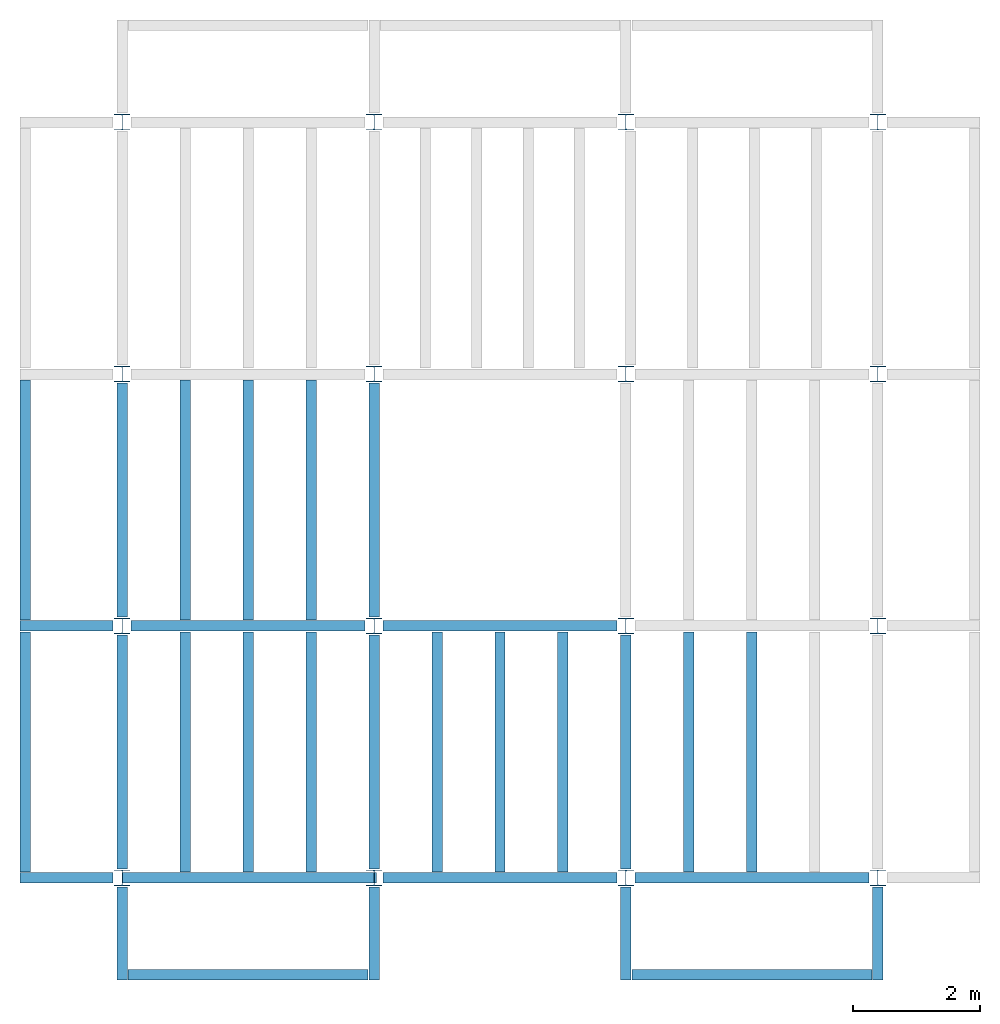
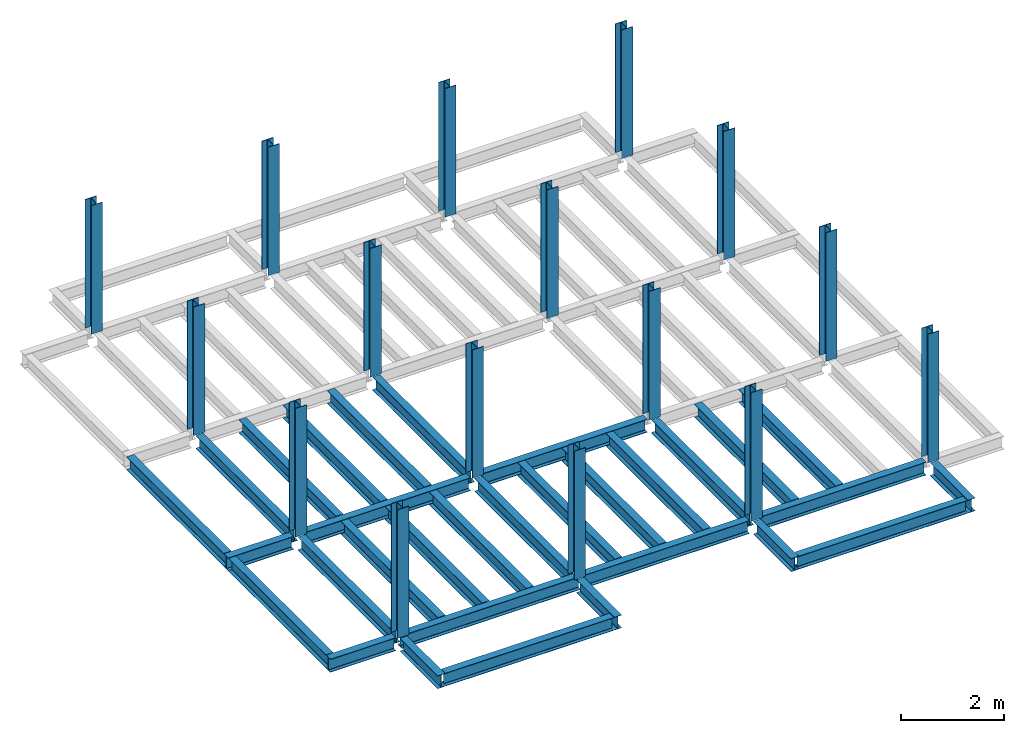
# One storey, part 1 of 3: 31 beams, 16 columns, 4 elements without a shape of their own.
"""IFC4 building model written with IfcOpenShell, lengths in feet."""

from ifc_helpers import new_model, entity, si_unit, converted_unit, derived_unit, direction, frame, origin, origin_2d, place, context, subcontext, project, spatial, line, arc, indexed_curve, i_section, outline, extrude, source, transform, mapped, material, type_object, type_shapes, element, aggregate, save


model = new_model("IFC4")

# Units and contexts
model_context = context("Model", 3, precision=0.0001, world=origin(), true_north=direction((6.123233995736766e-17, 1.0)))
plan_context = context("Plan", 3, precision=0.0001, world=origin(), true_north=direction((6.123233995736766e-17, 1.0)))
body_context = subcontext(model_context, "Body", "Model", "MODEL_VIEW")
ifc_project = project(units=[converted_unit("LENGTHUNIT", "FOOT", entity("IfcLengthMeasure", 0.3048), si_unit("LENGTHUNIT", "METRE"), dimensions=[1, 0, 0, 0, 0, 0, 0]), converted_unit("AREAUNIT", "SQUARE FOOT", entity("IfcAreaMeasure", 0.09290304), si_unit("AREAUNIT", "SQUARE_METRE"), dimensions=[2, 0, 0, 0, 0, 0, 0]), converted_unit("PLANEANGLEUNIT", "DEGREE", entity("IfcPlaneAngleMeasure", 0.017453292519943278), si_unit("PLANEANGLEUNIT", "RADIAN"), dimensions=[0, 0, 0, 0, 0, 0, 0]), converted_unit("VOLUMEUNIT", "CUBIC FOOT", entity("IfcVolumeMeasure", 0.028316846592000004), si_unit("VOLUMEUNIT", "CUBIC_METRE"), dimensions=[3, 0, 0, 0, 0, 0, 0]), si_unit("PRESSUREUNIT", "PASCAL"), derived_unit("MASSDENSITYUNIT", [(si_unit("MASSUNIT", "GRAM", prefix="KILO"), 1), (si_unit("LENGTHUNIT", "METRE"), -3)]), derived_unit("VAPORPERMEABILITYUNIT", [(si_unit("LENGTHUNIT", "METRE"), -1), (si_unit("TIMEUNIT", "SECOND"), 1)]), derived_unit("USERDEFINED", [(si_unit("MASSUNIT", "GRAM", prefix="KILO"), 1), (si_unit("LENGTHUNIT", "METRE"), 3), (si_unit("TIMEUNIT", "SECOND"), -3), (si_unit("ELECTRICCURRENTUNIT", "AMPERE"), -2)]), derived_unit("MODULUSOFELASTICITYUNIT", [(si_unit("MASSUNIT", "GRAM", prefix="KILO"), 1), (si_unit("LENGTHUNIT", "METRE"), -1), (si_unit("TIMEUNIT", "SECOND"), -2)]), derived_unit("THERMALEXPANSIONCOEFFICIENTUNIT", [(si_unit("THERMODYNAMICTEMPERATUREUNIT", "KELVIN"), -1)]), derived_unit("SPECIFICHEATCAPACITYUNIT", [(si_unit("TIMEUNIT", "SECOND"), -2), (si_unit("THERMODYNAMICTEMPERATUREUNIT", "KELVIN"), -1), (si_unit("LENGTHUNIT", "METRE"), 2)]), derived_unit("THERMALCONDUCTANCEUNIT", [(si_unit("MASSUNIT", "GRAM", prefix="KILO"), 1), (si_unit("TIMEUNIT", "SECOND"), -3), (si_unit("THERMODYNAMICTEMPERATUREUNIT", "KELVIN"), -1), (si_unit("LENGTHUNIT", "METRE"), 1)])], contexts=[model_context, plan_context])

# Site, building, storey
site_placement = place(None, origin())
site = spatial("IfcSite", under=ifc_project, at=site_placement, CompositionType="ELEMENT")
building_placement = place(site_placement, origin())
building = spatial("IfcBuilding", under=site, at=building_placement, CompositionType="ELEMENT")
storey_placement = place(building_placement, frame((0.0, 0.0, 109.875)))
storey = spatial("IfcBuildingStorey", under=building, at=storey_placement, Name="STR 12", CompositionType="ELEMENT", Elevation=109.875)

# Columns
ifc_material = material(Name="Steel ASTM A992", Category="Metal")
column_type = type_object("IfcColumnType", Name="W10X49", PredefinedType="COLUMN", material=ifc_material)
shared_shape_1 = source(origin(), body_context, "Body", "SweptSolid", [
    extrude(outline(indexed_curve([(-0.41666666666666663, -0.4166666666666676), (0.41666666666666663, -0.4166666666666676), (0.41666666666666663, -0.3699999999999996), (0.055833333333333846, -0.3699999999999996), (0.02637055078389421, -0.35779611588277277), (0.014166666666666636, -0.32833333333333287), (0.01416666666666665, 0.32833333333333303), (0.026370550783893467, 0.3577961158827727), (0.05583333333333332, 0.3700000000000003), (0.41666666666666663, 0.3700000000000003), (0.41666666666666663, 0.4166666666666656), (-0.41666666666666663, 0.4166666666666656), (-0.41666666666666663, 0.3700000000000003), (-0.05583333333333365, 0.3700000000000003), (-0.02637055078389416, 0.3577961158827734), (-0.014166666666666685, 0.32833333333333387), (-0.014166666666666685, -0.32833333333333264), (-0.026370550783893578, -0.3577961158827721), (-0.055833333333333374, -0.3699999999999996), (-0.41666666666666663, -0.3699999999999996)], segments=[line(1, 2, 3, 4), arc(4, 5, 6), line(6, 7), arc(7, 8, 9), line(9, 10, 11, 12, 13, 14), arc(14, 15, 16), line(16, 17), arc(17, 18, 19), line(19, 20, 1)], self_intersect=False)), frame((0.0, 0.0, 109.875), z_axis=(0.0, 0.0, 1.0), x_axis=(-1.0, 0.0, 0.0)), (0.0, 0.0, 1.0), 10.0),
])
type_shapes(column_type, [shared_shape_1])
for number, where, z_axis, x_axis, name in (
    (1, (0.0, 0.0, -109.875), (0.0, 0.0, 1.0), (-1.0, 0.0, 0.0), "W10X49"),
    (2, (0.0, 13.0, -109.875), (0.0, 0.0, 1.0), (-1.0, 0.0, 0.0), "W10X49"),
    (3, (0.0, 26.0, -109.875), (0.0, 0.0, 1.0), (-1.0, 0.0, 0.0), "W10X49"),
    (4, (0.0, 39.0, -109.875), (0.0, 0.0, 1.0), (-1.0, 0.0, 0.0), "W10X49"),
    (5, (13.0, 0.0, -109.875), (0.0, 0.0, 1.0), (-1.0, 0.0, 0.0), "W10X49"),
    (6, (13.0, 13.0, -109.875), (0.0, 0.0, 1.0), (-1.0, 0.0, 0.0), "W10X49"),
    (7, (13.0, 26.0, -109.875), (0.0, 0.0, 1.0), (-1.0, 0.0, 0.0), "W10X49"),
    (8, (13.0, 39.0, -109.875), (0.0, 0.0, 1.0), (-1.0, 0.0, 0.0), "W10X49"),
    (9, (26.0, 0.0, -109.875), (0.0, 0.0, 1.0), (-1.0, 0.0, 0.0), "W10X49"),
    (10, (26.0, 13.0, -109.875), (0.0, 0.0, 1.0), (-1.0, 0.0, 0.0), "W10X49"),
    (11, (26.0, 26.0, -109.875), (0.0, 0.0, 1.0), (-1.0, 0.0, 0.0), "W10X49"),
    (12, (26.0, 39.0, -109.875), (0.0, 0.0, 1.0), (-1.0, 0.0, 0.0), "W10X49"),
    (13, (39.0, 0.0, -109.875), (0.0, 0.0, 1.0), (-1.0, 0.0, 0.0), "W10X49"),
    (14, (39.0, 13.0, -109.875), (0.0, 0.0, 1.0), (-1.0, 0.0, 0.0), "W10X49"),
    (15, (39.0, 26.0, -109.875), (0.0, 0.0, 1.0), (-1.0, 0.0, 0.0), "W10X49"),
    (16, (39.0, 39.0, -109.875), (0.0, 0.0, 1.0), (-1.0, 0.0, 0.0), "W10X49"),
):
    element("IfcColumn", number, at=place(storey_placement, frame(where, z_axis=z_axis, x_axis=x_axis)), inside=storey, type_object=column_type, material=ifc_material, Name=name, ObjectType="W Shapes-Column:W10X49", PredefinedType="COLUMN", context=body_context, shape_type="MappedRepresentation", body=[
        mapped(shared_shape_1, transform((0.0, 0.0, 0.0), scale=1.0)),
    ])

# Beams
beam_type_1 = type_object("IfcBeamType", Name="W12X26", PredefinedType="JOIST", material=ifc_material)
shared_shape_2 = source(origin(), body_context, "Body", "SweptSolid", [
    extrude(outline(indexed_curve([(-0.27041666666666714, -0.47666666666666574), (-0.27041666666666714, -0.5083333333333351), (0.2704166666666669, -0.5083333333333351), (0.2704166666666669, -0.47666666666666574), (0.03458333333333309, -0.47666666666666574), (0.016905663803669493, -0.46934433619632937), (0.009583333333333202, -0.4516666666666659), (0.0095833333333332, 0.45166666666666705), (0.01690566380366948, 0.4693443361963307), (0.03458333333333325, 0.4766666666666671), (0.2704166666666669, 0.4766666666666671), (0.2704166666666669, 0.5083333333333312), (-0.2704166666666655, 0.5083333333333312), (-0.2704166666666655, 0.4766666666666671), (-0.034583333333333514, 0.47666666666666707), (-0.016905663803669865, 0.46934433619633054), (-0.009583333333333737, 0.45166666666666694), (-0.009583333333333735, -0.4516666666666658), (-0.01690566380367013, -0.4693443361963295), (-0.03458333333333368, -0.47666666666666574)], segments=[line(1, 2, 3, 4, 5), arc(5, 6, 7), line(7, 8), arc(8, 9, 10), line(10, 11, 12, 13, 14, 15), arc(15, 16, 17), line(17, 18), arc(18, 19, 20), line(20, 1)], self_intersect=False)), frame((-6.103346456692914, 0.0, 0.0), z_axis=(-1.0, 0.0, 0.0), x_axis=(0.0, -1.0, 0.0)), (0.0, 0.0, -1.0), 12.083333333333323),
])
type_shapes(beam_type_1, [shared_shape_2])
beam_1_placement = place(storey_placement, frame((6.561679790026266, 13.0, -0.50833333333334)))
element("IfcBeam", 17, at=beam_1_placement, inside=storey, type_object=beam_type_1, material=ifc_material, Name="W12X26", ObjectType="W Shapes:W12X26", PredefinedType="JOIST", context=body_context, shape_type="MappedRepresentation", body=[
    mapped(shared_shape_2, transform((0.0, 0.0, 0.0), scale=1.0)),
])
for number, where, z_axis, x_axis, name in (
    (18, (0.0, 6.561679790026247, -0.50833333333334), (0.0, 0.0, 1.0), (0.0, 1.0, 0.0), "W12X26"),
    (19, (26.0, 6.561679790026162, -0.50833333333334), (0.0, 0.0, 1.0), (0.0, 1.0, 0.0), "W12X26"),
    (20, (13.0, 6.5616797900262025, -0.50833333333334), (0.0, 0.0, 1.0), (0.0, 1.0, 0.0), "W12X26"),
):
    element("IfcBeam", number, at=place(storey_placement, frame(where, z_axis=z_axis, x_axis=x_axis)), inside=storey, type_object=beam_type_1, material=ifc_material, Name=name, ObjectType="W Shapes:W12X26", PredefinedType="JOIST", context=body_context, shape_type="MappedRepresentation", body=[
        mapped(shared_shape_2, transform((0.0, 0.0, 0.0), scale=1.0)),
    ])
beam_type_2 = type_object("IfcBeamType", Name="W12X26", PredefinedType="JOIST", material=ifc_material)
shared_shape_3 = source(origin(), body_context, "Body", "SweptSolid", [
    extrude(outline(indexed_curve([(-0.27041666666666714, -0.47666666666666574), (-0.27041666666666714, -0.5083333333333351), (0.2704166666666669, -0.5083333333333351), (0.2704166666666669, -0.47666666666666574), (0.03458333333333309, -0.47666666666666574), (0.016905663803669493, -0.46934433619632937), (0.009583333333333202, -0.4516666666666659), (0.0095833333333332, 0.45166666666666705), (0.01690566380366948, 0.4693443361963307), (0.03458333333333325, 0.4766666666666671), (0.2704166666666669, 0.4766666666666671), (0.2704166666666669, 0.5083333333333312), (-0.2704166666666655, 0.5083333333333312), (-0.2704166666666655, 0.4766666666666671), (-0.034583333333333514, 0.47666666666666707), (-0.016905663803669865, 0.46934433619633054), (-0.009583333333333737, 0.45166666666666694), (-0.009583333333333735, -0.4516666666666658), (-0.01690566380367013, -0.4693443361963295), (-0.03458333333333368, -0.47666666666666574)], segments=[line(1, 2, 3, 4, 5), arc(5, 6, 7), line(7, 8), arc(8, 9, 10), line(10, 11, 12, 13, 14, 15), arc(15, 16, 17), line(17, 18), arc(18, 19, 20), line(20, 1)], self_intersect=False)), frame((-6.226706036745409, 0.0, 0.0), z_axis=(-1.0, 0.0, 0.0), x_axis=(0.0, -1.0, 0.0)), (0.0, 0.0, -1.0), 12.08333333333333),
])
type_shapes(beam_type_2, [shared_shape_3])
for number, where, name in (
    (21, (19.68503937007876, 13.0, -0.50833333333334), "W12X26"),
    (22, (19.68503937007874, 0.0, -0.50833333333334), "W12X26"),
):
    element("IfcBeam", number, at=place(storey_placement, frame(where)), inside=storey, type_object=beam_type_2, material=ifc_material, Name=name, ObjectType="W Shapes:W12X26", PredefinedType="JOIST", context=body_context, shape_type="MappedRepresentation", body=[
        mapped(shared_shape_3, transform((0.0, 0.0, 0.0), scale=1.0)),
    ])
for number, where, z_axis, x_axis, name in (
    (23, (0.0, 19.68503937007874, -0.50833333333334), (0.0, 0.0, 1.0), (0.0, 1.0, 0.0), "W12X26"),
    (24, (13.0, 19.685039370078698, -0.50833333333334), (0.0, 0.0, 1.0), (0.0, 1.0, 0.0), "W12X26"),
):
    element("IfcBeam", number, at=place(storey_placement, frame(where, z_axis=z_axis, x_axis=x_axis)), inside=storey, type_object=beam_type_2, material=ifc_material, Name=name, ObjectType="W Shapes:W12X26", PredefinedType="JOIST", context=body_context, shape_type="MappedRepresentation", body=[
        mapped(shared_shape_3, transform((0.0, 0.0, 0.0), scale=1.0)),
    ])

# Assembly, beams
assembly_1_placement = place(storey_placement, origin())
assembly_1 = element("IfcElementAssembly", 25, at=assembly_1_placement, inside=storey, Name="Structural Framing System", ObjectType="Structural Beam System:Structural Framing System", AssemblyPlace="NOTDEFINED", PredefinedType="BEAM_GRID")
beam_type_3 = type_object("IfcBeamType", Name="W12X26", PredefinedType="JOIST", material=ifc_material)
shared_shape_4 = source(origin(), body_context, "Body", "SweptSolid", [
    extrude(outline(indexed_curve([(-0.27041666666666714, -0.47666666666666574), (-0.27041666666666714, -0.5083333333333351), (0.2704166666666669, -0.5083333333333351), (0.2704166666666669, -0.47666666666666574), (0.03458333333333309, -0.47666666666666574), (0.016905663803669493, -0.46934433619632937), (0.009583333333333202, -0.4516666666666659), (0.0095833333333332, 0.45166666666666705), (0.01690566380366948, 0.4693443361963307), (0.03458333333333325, 0.4766666666666671), (0.2704166666666669, 0.4766666666666671), (0.2704166666666669, 0.5083333333333312), (-0.2704166666666655, 0.5083333333333312), (-0.2704166666666655, 0.4766666666666671), (-0.034583333333333514, 0.47666666666666707), (-0.016905663803669865, 0.46934433619633054), (-0.009583333333333737, 0.45166666666666694), (-0.009583333333333735, -0.4516666666666658), (-0.01690566380367013, -0.4693443361963295), (-0.03458333333333368, -0.47666666666666574)], segments=[line(1, 2, 3, 4, 5), arc(5, 6, 7), line(7, 8), arc(8, 9, 10), line(10, 11, 12, 13, 14, 15), arc(15, 16, 17), line(17, 18), arc(18, 19, 20), line(20, 1)], self_intersect=False)), frame((-6.187916666666566, 0.0, 0.0), z_axis=(-1.0, 0.0, 0.0), x_axis=(0.0, -1.0, 0.0)), (0.0, 0.0, -1.0), 12.375833333333075),
])
type_shapes(beam_type_3, [shared_shape_4])
beam_2_placement = place(assembly_1_placement, frame((3.250000000000031, 6.499999999999844, -0.50833333333334), z_axis=(0.0, 0.0, 1.0), x_axis=(0.0, 1.0, 0.0)))
beam_2 = element("IfcBeam", 26, at=beam_2_placement, type_object=beam_type_3, material=ifc_material, Name="W12X26", ObjectType="W Shapes:W12X26", PredefinedType="JOIST", context=body_context, shape_type="MappedRepresentation", body=[
    mapped(shared_shape_4, transform((0.0, 0.0, 0.0), scale=1.0)),
])
beam_3_placement = place(assembly_1_placement, frame((6.5000000000000515, 6.4999999999998455, -0.50833333333334), z_axis=(0.0, 0.0, 1.0), x_axis=(0.0, 1.0, 0.0)))
beam_3 = element("IfcBeam", 27, at=beam_3_placement, type_object=beam_type_3, material=ifc_material, Name="W12X26", ObjectType="W Shapes:W12X26", PredefinedType="JOIST", context=body_context, shape_type="MappedRepresentation", body=[
    mapped(shared_shape_4, transform((0.0, 0.0, 0.0), scale=1.0)),
])
beam_4_placement = place(assembly_1_placement, frame((9.750000000000073, 6.499999999999844, -0.50833333333334), z_axis=(0.0, 0.0, 1.0), x_axis=(0.0, 1.0, 0.0)))
beam_4 = element("IfcBeam", 28, at=beam_4_placement, type_object=beam_type_3, material=ifc_material, Name="W12X26", ObjectType="W Shapes:W12X26", PredefinedType="JOIST", context=body_context, shape_type="MappedRepresentation", body=[
    mapped(shared_shape_4, transform((0.0, 0.0, 0.0), scale=1.0)),
])
aggregate(assembly_1, [beam_2, beam_3, beam_4])

assembly_2_placement = place(storey_placement, origin())
assembly_2 = element("IfcElementAssembly", 29, at=assembly_2_placement, inside=storey, Name="Structural Framing System", ObjectType="Structural Beam System:Structural Framing System", AssemblyPlace="NOTDEFINED", PredefinedType="BEAM_GRID")
beam_5_placement = place(assembly_2_placement, frame((3.2500000000000515, 19.49999999999968, -0.50833333333334), z_axis=(0.0, 0.0, 1.0), x_axis=(0.0, 1.0, 0.0)))
beam_5 = element("IfcBeam", 30, at=beam_5_placement, type_object=beam_type_3, material=ifc_material, Name="W12X26", ObjectType="W Shapes:W12X26", PredefinedType="JOIST", context=body_context, shape_type="MappedRepresentation", body=[
    mapped(shared_shape_4, transform((0.0, 0.0, 0.0), scale=1.0)),
])
beam_6_placement = place(assembly_2_placement, frame((6.500000000000073, 19.499999999999666, -0.50833333333334), z_axis=(0.0, 0.0, 1.0), x_axis=(0.0, 1.0, 0.0)))
beam_6 = element("IfcBeam", 31, at=beam_6_placement, type_object=beam_type_3, material=ifc_material, Name="W12X26", ObjectType="W Shapes:W12X26", PredefinedType="JOIST", context=body_context, shape_type="MappedRepresentation", body=[
    mapped(shared_shape_4, transform((0.0, 0.0, 0.0), scale=1.0)),
])
beam_7_placement = place(assembly_2_placement, frame((9.750000000000094, 19.49999999999966, -0.50833333333334), z_axis=(0.0, 0.0, 1.0), x_axis=(0.0, 1.0, 0.0)))
beam_7 = element("IfcBeam", 32, at=beam_7_placement, type_object=beam_type_3, material=ifc_material, Name="W12X26", ObjectType="W Shapes:W12X26", PredefinedType="JOIST", context=body_context, shape_type="MappedRepresentation", body=[
    mapped(shared_shape_4, transform((0.0, 0.0, 0.0), scale=1.0)),
])
aggregate(assembly_2, [beam_5, beam_6, beam_7])

assembly_3_placement = place(storey_placement, origin())
assembly_3 = element("IfcElementAssembly", 33, at=assembly_3_placement, inside=storey, Name="Structural Framing System", ObjectType="Structural Beam System:Structural Framing System", AssemblyPlace="NOTDEFINED", PredefinedType="BEAM_GRID")
beam_8_placement = place(assembly_3_placement, frame((16.25000000000009, 6.499999999999801, -0.50833333333334), z_axis=(0.0, 0.0, 1.0), x_axis=(0.0, 1.0, 0.0)))
beam_8 = element("IfcBeam", 34, at=beam_8_placement, type_object=beam_type_3, material=ifc_material, Name="W12X26", ObjectType="W Shapes:W12X26", PredefinedType="JOIST", context=body_context, shape_type="MappedRepresentation", body=[
    mapped(shared_shape_4, transform((0.0, 0.0, 0.0), scale=1.0)),
])
beam_9_placement = place(assembly_3_placement, frame((19.500000000000096, 6.499999999999801, -0.50833333333334), z_axis=(0.0, 0.0, 1.0), x_axis=(0.0, 1.0, 0.0)))
beam_9 = element("IfcBeam", 35, at=beam_9_placement, type_object=beam_type_3, material=ifc_material, Name="W12X26", ObjectType="W Shapes:W12X26", PredefinedType="JOIST", context=body_context, shape_type="MappedRepresentation", body=[
    mapped(shared_shape_4, transform((0.0, 0.0, 0.0), scale=1.0)),
])
beam_10_placement = place(assembly_3_placement, frame((22.750000000000103, 6.499999999999801, -0.50833333333334), z_axis=(0.0, 0.0, 1.0), x_axis=(0.0, 1.0, 0.0)))
beam_10 = element("IfcBeam", 36, at=beam_10_placement, type_object=beam_type_3, material=ifc_material, Name="W12X26", ObjectType="W Shapes:W12X26", PredefinedType="JOIST", context=body_context, shape_type="MappedRepresentation", body=[
    mapped(shared_shape_4, transform((0.0, 0.0, 0.0), scale=1.0)),
])
aggregate(assembly_3, [beam_8, beam_9, beam_10])

assembly_4_placement = place(storey_placement, origin())
assembly_4 = element("IfcElementAssembly", 37, at=assembly_4_placement, inside=storey, Name="Structural Framing System", ObjectType="Structural Beam System:Structural Framing System", AssemblyPlace="NOTDEFINED", PredefinedType="BEAM_GRID")
beam_11_placement = place(assembly_4_placement, frame((29.2500000000001, 6.49999999999975, -0.50833333333334), z_axis=(0.0, 0.0, 1.0), x_axis=(0.0, 1.0, 0.0)))
beam_11 = element("IfcBeam", 38, at=beam_11_placement, type_object=beam_type_3, material=ifc_material, Name="W12X26", ObjectType="W Shapes:W12X26", PredefinedType="JOIST", context=body_context, shape_type="MappedRepresentation", body=[
    mapped(shared_shape_4, transform((0.0, 0.0, 0.0), scale=1.0)),
])
beam_12_placement = place(assembly_4_placement, frame((32.5000000000001, 6.499999999999737, -0.50833333333334), z_axis=(0.0, 0.0, 1.0), x_axis=(0.0, 1.0, 0.0)))
beam_12 = element("IfcBeam", 39, at=beam_12_placement, type_object=beam_type_3, material=ifc_material, Name="W12X26", ObjectType="W Shapes:W12X26", PredefinedType="JOIST", context=body_context, shape_type="MappedRepresentation", body=[
    mapped(shared_shape_4, transform((0.0, 0.0, 0.0), scale=1.0)),
])
aggregate(assembly_4, [beam_11, beam_12])

# Beams
for number, where, z_axis, x_axis, name in (
    (40, (-5.0, 6.499999999999858, -0.50833333333334), (0.0, 0.0, 1.0), (0.0, -1.0, 0.0), "W12X26"),
    (41, (-5.0, 19.499999999999705, -0.50833333333334), (0.0, 0.0, 1.0), (0.0, 1.0, 0.0), "W12X26"),
):
    element("IfcBeam", number, at=place(storey_placement, frame(where, z_axis=z_axis, x_axis=x_axis)), inside=storey, type_object=beam_type_3, material=ifc_material, Name=name, ObjectType="W Shapes:W12X26", PredefinedType="JOIST", context=body_context, shape_type="MappedRepresentation", body=[
        mapped(shared_shape_4, transform((0.0, 0.0, 0.0), scale=1.0)),
    ])
beam_type_4 = type_object("IfcBeamType", Name="W12X26", PredefinedType="JOIST", material=ifc_material)
shared_shape_5 = source(origin(), body_context, "Body", "SweptSolid", [
    extrude(outline(indexed_curve([(-0.27041666666666714, -0.47666666666666574), (-0.27041666666666714, -0.5083333333333351), (0.2704166666666669, -0.5083333333333351), (0.2704166666666669, -0.47666666666666574), (0.03458333333333309, -0.47666666666666574), (0.016905663803669493, -0.46934433619632937), (0.009583333333333202, -0.4516666666666659), (0.0095833333333332, 0.45166666666666705), (0.01690566380366948, 0.4693443361963307), (0.03458333333333325, 0.4766666666666671), (0.2704166666666669, 0.4766666666666671), (0.2704166666666669, 0.5083333333333312), (-0.2704166666666655, 0.5083333333333312), (-0.2704166666666655, 0.4766666666666671), (-0.034583333333333514, 0.47666666666666707), (-0.016905663803669865, 0.46934433619633054), (-0.009583333333333737, 0.45166666666666694), (-0.009583333333333735, -0.4516666666666658), (-0.01690566380367013, -0.4693443361963295), (-0.03458333333333368, -0.47666666666666574)], segments=[line(1, 2, 3, 4, 5), arc(5, 6, 7), line(7, 8), arc(8, 9, 10), line(10, 11, 12, 13, 14, 15), arc(15, 16, 17), line(17, 18), arc(18, 19, 20), line(20, 1)], self_intersect=False)), frame((-6.165026246719308, 0.0, 0.0), z_axis=(-1.0, 0.0, 0.0), x_axis=(0.0, -1.0, 0.0)), (0.0, 0.0, -1.0), 12.08333333333334),
])
type_shapes(beam_type_4, [shared_shape_5])
beam_13_placement = place(storey_placement, frame((32.623359580052536, 0.0, -0.50833333333334)))
element("IfcBeam", 42, at=beam_13_placement, inside=storey, type_object=beam_type_4, material=ifc_material, Name="W12X26", ObjectType="W Shapes:W12X26", PredefinedType="JOIST", context=body_context, shape_type="MappedRepresentation", body=[
    mapped(shared_shape_5, transform((0.0, 0.0, 0.0), scale=1.0)),
])
beam_type_5 = type_object("IfcBeamType", Name="W12X26", PredefinedType="JOIST", material=ifc_material)
shared_shape_6 = source(origin(), body_context, "Body", "SweptSolid", [
    extrude(outline(indexed_curve([(0.47666666666666574, -0.2704166666666672), (0.5083333333333351, -0.2704166666666672), (0.5083333333333351, 0.27041666666666686), (0.47666666666666574, 0.27041666666666686), (0.47666666666666574, 0.03458333333333307), (0.46934433619632937, 0.016905663803669473), (0.4516666666666659, 0.00958333333333318), (-0.45166666666666705, 0.00958333333333318), (-0.4693443361963307, 0.01690566380366946), (-0.4766666666666671, 0.03458333333333323), (-0.4766666666666671, 0.27041666666666686), (-0.5083333333333312, 0.27041666666666686), (-0.5083333333333312, -0.27041666666666553), (-0.4766666666666671, -0.27041666666666553), (-0.47666666666666707, -0.034583333333333535), (-0.46934433619633054, -0.016905663803669885), (-0.45166666666666694, -0.00958333333333376), (0.4516666666666658, -0.009583333333333756), (0.4693443361963295, -0.01690566380367015), (0.47666666666666574, -0.0345833333333337)], segments=[line(1, 2, 3, 4, 5), arc(5, 6, 7), line(7, 8), arc(8, 9, 10), line(10, 11, 12, 13, 14, 15), arc(15, 16, 17), line(17, 18), arc(18, 19, 20), line(20, 1)], self_intersect=False)), frame((-2.0416666666666208, 0.0, 0.0), z_axis=(1.0, 0.0, 0.0), x_axis=(0.0, 0.0, -1.0)), (0.0, 0.0, 1.0), 4.812083333333336),
])
type_shapes(beam_type_5, [shared_shape_6])
for number, where, z_axis, x_axis, name in (
    (43, (39.0, -2.50000000000058, -0.50833333333334), (0.0, 0.0, 1.0), (0.0, -1.0, 0.0), "W12X26"),
    (44, (26.0, -2.500000000000538, -0.50833333333334), (0.0, 0.0, 1.0), (0.0, -1.0, 0.0), "W12X26"),
    (45, (-2.499999999999853, 13.0, -0.50833333333334), (0.0, 0.0, 1.0), (-1.0, 0.0, 0.0), "W12X26"),
    (46, (-2.4999999999998743, 0.0, -0.50833333333334), (0.0, 0.0, 1.0), (-1.0, 0.0, 0.0), "W12X26"),
):
    element("IfcBeam", number, at=place(storey_placement, frame(where, z_axis=z_axis, x_axis=x_axis)), inside=storey, type_object=beam_type_5, material=ifc_material, Name=name, ObjectType="W Shapes:W12X26", PredefinedType="JOIST", context=body_context, shape_type="MappedRepresentation", body=[
        mapped(shared_shape_6, transform((0.0, 0.0, 0.0), scale=1.0)),
    ])
beam_type_6 = type_object("IfcBeamType", Name="W12X26", PredefinedType="JOIST", material=ifc_material)
shared_shape_7 = source(origin(), body_context, "Body", "SweptSolid", [
    extrude(outline(indexed_curve([(0.47666666666666574, -0.2704166666666672), (0.5083333333333351, -0.2704166666666672), (0.5083333333333351, 0.27041666666666686), (0.47666666666666574, 0.27041666666666686), (0.47666666666666574, 0.03458333333333307), (0.46934433619632937, 0.016905663803669473), (0.4516666666666659, 0.00958333333333318), (-0.45166666666666705, 0.00958333333333318), (-0.4693443361963307, 0.01690566380366946), (-0.4766666666666671, 0.03458333333333323), (-0.4766666666666671, 0.27041666666666686), (-0.5083333333333312, 0.27041666666666686), (-0.5083333333333312, -0.27041666666666553), (-0.4766666666666671, -0.27041666666666553), (-0.47666666666666707, -0.034583333333333535), (-0.46934433619633054, -0.016905663803669885), (-0.45166666666666694, -0.00958333333333376), (0.4516666666666658, -0.009583333333333756), (0.4693443361963295, -0.01690566380367015), (0.47666666666666574, -0.0345833333333337)], segments=[line(1, 2, 3, 4, 5), arc(5, 6, 7), line(7, 8), arc(8, 9, 10), line(10, 11, 12, 13, 14, 15), arc(15, 16, 17), line(17, 18), arc(18, 19, 20), line(20, 1)], self_intersect=False)), frame((-6.187916666666685, 0.0, 0.0), z_axis=(1.0, 0.0, 0.0), x_axis=(0.0, 0.0, -1.0)), (0.0, 0.0, 1.0), 12.375833333333318),
])
type_shapes(beam_type_6, [shared_shape_7])
beam_14_placement = place(storey_placement, frame((32.50000000000002, -5.0, -0.50833333333334)))
element("IfcBeam", 47, at=beam_14_placement, inside=storey, type_object=beam_type_6, material=ifc_material, Name="W Shapes:W12X26", ObjectType="W Shapes:W12X26", PredefinedType="JOIST", context=body_context, shape_type="MappedRepresentation", body=[
    mapped(shared_shape_7, transform((0.0, 0.0, 0.0), scale=1.0)),
])
beam_type_7 = type_object("IfcBeamType", Name="W12X26", PredefinedType="JOIST", material=ifc_material)
shared_shape_8 = source(origin(), body_context, "Body", "SweptSolid", [
    extrude(outline(indexed_curve([(-0.2704166666666641, -0.50833333333334), (0.27041666666666764, -0.50833333333334), (0.27041666666666764, -0.4766666666666737), (0.03458333333333563, -0.4766666666666879), (0.01690566380367109, -0.4693443361963432), (0.009583333333335275, -0.4516666666666822), (0.009583333333335275, 0.4516666666666538), (0.01690566380367109, 0.46934433619631477), (0.03458333333333563, 0.47666666666665947), (0.2704166666666694, 0.47666666666665947), (0.27041666666666764, 0.5083333333333258), (-0.27041666666666586, 0.5083333333333258), (-0.27041666666666586, 0.47666666666665947), (-0.03458333333333208, 0.47666666666665947), (-0.016905663803667537, 0.46934433619631477), (-0.009583333333331723, 0.4516666666666538), (-0.009583333333331723, -0.4516666666666822), (-0.016905663803667537, -0.4693443361963432), (-0.03458333333333208, -0.4766666666666737), (-0.27041666666666586, -0.4766666666666737)], segments=[line(1, 2, 3, 4), arc(4, 5, 6), line(6, 7), arc(7, 8, 9), line(9, 10, 11, 12, 13, 14), arc(14, 15, 16), line(16, 17), arc(17, 18, 19), line(19, 20, 1)], self_intersect=False)), frame((13.0, -0.45833333333387627, 109.36666666666663), z_axis=(0.0, -1.0, 0.0), x_axis=(-1.0, 0.0, 0.0)), (0.0, 0.0, 1.0), 4.812083333333337),
])
type_shapes(beam_type_7, [shared_shape_8])
beam_15_placement = place(storey_placement, frame((0.0, 0.0, -109.875)))
element("IfcBeam", 48, at=beam_15_placement, inside=storey, type_object=beam_type_7, material=ifc_material, Name="W12X26", ObjectType="W Shapes:W12X26", PredefinedType="JOIST", context=body_context, shape_type="MappedRepresentation", body=[
    mapped(shared_shape_8, transform((0.0, 0.0, 0.0), scale=1.0)),
])
beam_type_8 = type_object("IfcBeamType", Name="W12X26", PredefinedType="JOIST", material=ifc_material)
shared_shape_9 = source(origin(), body_context, "Body", "SweptSolid", [
    extrude(outline(indexed_curve([(-0.5083333333333258, -0.270416666666665), (-0.47666666666665947, -0.270416666666665), (-0.4766666666666737, -0.034583333333333854), (-0.469344336196329, -0.016905663803669313), (-0.451666666666668, -0.009583333333333499), (0.451666666666668, -0.009583333333333499), (0.469344336196329, -0.016905663803669313), (0.4766666666666737, -0.034583333333332966), (0.4766666666666737, -0.27041666666666675), (0.50833333333334, -0.27041666666666675), (0.50833333333334, 0.27041666666666675), (0.4766666666666737, 0.27041666666666764), (0.4766666666666737, 0.034583333333333854), (0.469344336196329, 0.016905663803669313), (0.451666666666668, 0.009583333333333499), (-0.451666666666668, 0.009583333333333499), (-0.469344336196329, 0.016905663803669313), (-0.47666666666665947, 0.034583333333332966), (-0.47666666666665947, 0.27041666666666675), (-0.5083333333333258, 0.27041666666666764)], segments=[line(1, 2, 3), arc(3, 4, 5), line(5, 6), arc(6, 7, 8), line(8, 9, 10, 11, 12, 13), arc(13, 14, 15), line(15, 16), arc(16, 17, 18), line(18, 19, 20, 1)], self_intersect=False)), frame((0.3120833333333186, -5.0, 109.36666666666665), z_axis=(1.0, 0.0, 0.0), x_axis=(0.0, 0.0, -1.0)), (0.0, 0.0, 1.0), 12.37583333333332),
])
type_shapes(beam_type_8, [shared_shape_9])
beam_16_placement = place(storey_placement, frame((0.0, 0.0, -109.875)))
element("IfcBeam", 49, at=beam_16_placement, inside=storey, type_object=beam_type_8, material=ifc_material, Name="W Shapes:W12X26", ObjectType="W Shapes:W12X26", PredefinedType="JOIST", context=body_context, shape_type="MappedRepresentation", body=[
    mapped(shared_shape_9, transform((0.0, 0.0, 0.0), scale=1.0)),
])
beam_type_9 = type_object("IfcBeamType", Name="W12X26", PredefinedType="JOIST", material=ifc_material)
shared_shape_10 = source(origin(), body_context, "Body", "SweptSolid", [
    extrude(outline(indexed_curve([(-0.27041666666666686, -0.50833333333334), (0.27041666666666553, -0.50833333333334), (0.27041666666666553, -0.4766666666666737), (0.03458333333333355, -0.4766666666666879), (0.016905663803669275, -0.4693443361963432), (0.009583333333333723, -0.4516666666666822), (0.009583333333333218, 0.4516666666666538), (0.01690566380366942, 0.46934433619631477), (0.034583333333333716, 0.47666666666665947), (0.2704166666666672, 0.47666666666665947), (0.2704166666666672, 0.5083333333333258), (-0.27041666666666686, 0.5083333333333258), (-0.27041666666666686, 0.47666666666665947), (-0.03458333333333308, 0.47666666666665947), (-0.01690566380366875, 0.46934433619631477), (-0.009583333333333164, 0.4516666666666538), (-0.009583333333332694, -0.4516666666666822), (-0.01690566380366881, -0.4693443361963432), (-0.03458333333333319, -0.4766666666666737), (-0.27041666666666686, -0.4766666666666737)], segments=[line(1, 2, 3, 4), arc(4, 5, 6), line(6, 7), arc(7, 8, 9), line(9, 10, 11, 12, 13, 14), arc(14, 15, 16), line(16, 17), arc(17, 18, 19), line(19, 20, 1)], self_intersect=False)), frame((0.0, -0.45833333333383364, 109.36666666666663), z_axis=(0.0, -1.0, 0.0), x_axis=(-1.0, 0.0, 0.0)), (0.0, 0.0, 1.0), 4.812083333333337),
])
type_shapes(beam_type_9, [shared_shape_10])
beam_17_placement = place(storey_placement, frame((0.0, 0.0, -109.875)))
element("IfcBeam", 50, at=beam_17_placement, inside=storey, type_object=beam_type_9, material=ifc_material, Name="W12X26", ObjectType="W Shapes:W12X26", PredefinedType="JOIST", context=body_context, shape_type="MappedRepresentation", body=[
    mapped(shared_shape_10, transform((0.0, 0.0, 0.0), scale=1.0)),
])
beam_type_10 = type_object("IfcBeamType", Name="W12X26", PredefinedType="BEAM")
beam_18_placement = place(storey_placement, frame((0.0, 0.0, -0.50833333333334), z_axis=(-1.0, 0.0, 0.0), x_axis=(0.0, -1.0, 0.0)))
element("IfcBeam", 51, at=beam_18_placement, inside=storey, type_object=beam_type_10, material=ifc_material, Name="W12X26", ObjectType="W12X26", context=model_context, shape_type="SweptSolid", body=[
    extrude(i_section(OverallWidth=0.5408333333333333, OverallDepth=1.0166666666666666, WebThickness=0.019166666666666665, FlangeThickness=0.03166666666666666, FilletRadius=0.024999999999999998, at=origin_2d()), origin(), (0.0, 0.0, -1.0), 13.123359580052494),
])

save(model, "model.ifc")
